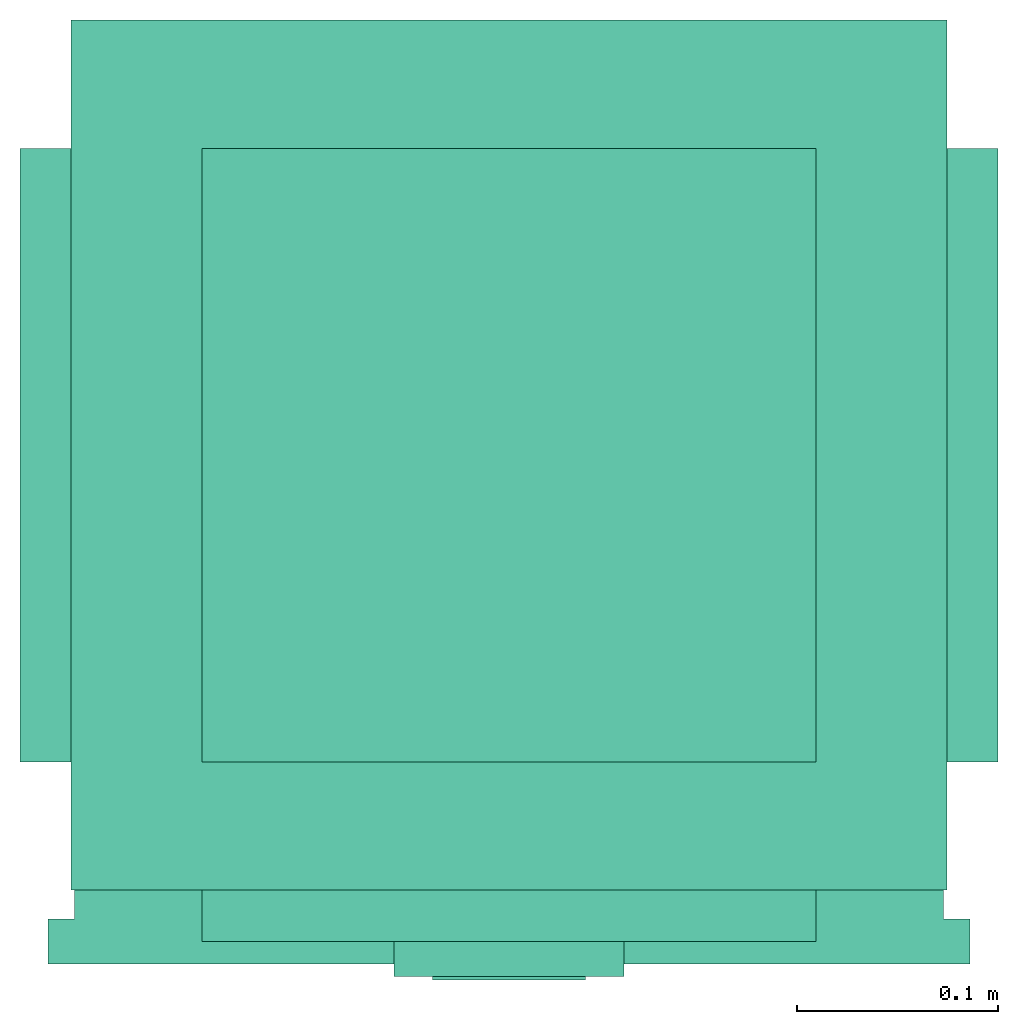
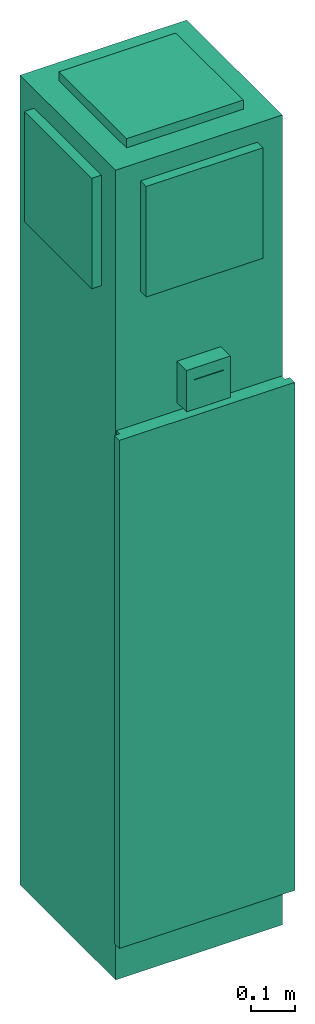
# One storey: 1 energy conversion device.
"""IFC2X3 building model written with IfcOpenShell, lengths in metres."""

from ifc_helpers import new_model, entity, si_unit, converted_unit, origin, origin_with_axes, place, context, subcontext, project, spatial, faceted_brep, type_object, element, save


model = new_model("IFC2X3")

# Units and contexts
model_context = context("Model", 3, precision=1e-05, world=origin())
body_context = subcontext(model_context, "Body", "Model", "MODEL_VIEW")
ifc_project = project(units=[si_unit("LENGTHUNIT", "METRE"), si_unit("AREAUNIT", "SQUARE_METRE"), si_unit("VOLUMEUNIT", "CUBIC_METRE"), converted_unit("PLANEANGLEUNIT", "DEGREE", entity("IfcPlaneAngleMeasure", 0.0174532925199433), si_unit("PLANEANGLEUNIT", "RADIAN"), dimensions=[0, 0, 0, 0, 0, 0, 0]), si_unit("SOLIDANGLEUNIT", "STERADIAN"), si_unit("MASSUNIT", "GRAM"), si_unit("TIMEUNIT", "SECOND"), si_unit("THERMODYNAMICTEMPERATUREUNIT", "DEGREE_CELSIUS"), si_unit("LUMINOUSINTENSITYUNIT", "LUMEN")], contexts=[model_context])

# Site, building, storey
site_placement = place(None, origin_with_axes())
site = spatial("IfcSite", under=ifc_project, at=site_placement, CompositionType="ELEMENT")
building_placement = place(site_placement, origin_with_axes())
building = spatial("IfcBuilding", under=site, at=building_placement, CompositionType="ELEMENT")
storey_placement = place(building_placement, origin_with_axes())
storey = spatial("IfcBuildingStorey", under=building, at=storey_placement, CompositionType="ELEMENT", Elevation=0.0)

# Energy conversion device
heat_exchanger_type = type_object("IfcHeatExchangerType", Name="Hi Rise Fan Coil Unit (FCU)", PredefinedType="NOTDEFINED")
energy_conversion_device_placement = place(storey_placement, origin_with_axes())
element("IfcEnergyConversionDevice", 1, at=energy_conversion_device_placement, inside=storey, type_object=heat_exchanger_type, Name="Rise Fan Coil Unit (FCU)", context=body_context, shape_type="Brep", body=[
    faceted_brep([(-0.129934510803223, 0.1524, 2.18225827026367), (-0.129934510803223, 0.1524, 1.87745827026367), (-0.155334510803223, 0.1524, 1.87745827026367), (-0.155334510803223, 0.1524, 2.18225827026367), (-0.129934510803223, -0.1524, 1.87745827026367), (-0.155334510803223, -0.1524, 1.87745827026367), (-0.129934510803223, -0.1524, 2.18225827026367), (-0.155334510803223, -0.1524, 2.18225827026367)], [[[0, 1, 2]], [[2, 3, 0]], [[1, 4, 5]], [[5, 2, 1]], [[4, 6, 7]], [[7, 5, 4]], [[6, 0, 3]], [[3, 7, 6]], [[6, 1, 0]], [[1, 6, 4]], [[7, 3, 2]], [[2, 5, 7]]]),
    faceted_brep([(-0.129934510803223, -7.21911419532262e-16, 2.23457697601318), (-0.129934510803223, 0.216141288566589, 2.23457697601318), (-0.129934510803223, 0.216141288566589, 0.000123923291545361), (-0.129934510803223, -7.21911419532262e-16, 0.000123923291545361), (0.305040489196778, 0.216141288566589, 2.23457697601318), (0.305040489196778, 0.216141288566589, 0.000123923291545361), (0.305040489196778, -0.216141288566589, 2.23457697601318), (0.305040489196778, -0.216141288566589, 0.000123923291545361), (-0.129934510803223, -0.216141288566589, 2.23457697601318), (-0.129934510803223, -0.216141288566589, 0.000123923291545361)], [[[0, 1, 2]], [[2, 3, 0]], [[1, 4, 5]], [[5, 2, 1]], [[4, 6, 7]], [[7, 5, 4]], [[6, 8, 9]], [[9, 7, 6]], [[8, 0, 3]], [[3, 9, 8]], [[0, 4, 1]], [[8, 6, 0]], [[4, 0, 6]], [[3, 2, 5]], [[9, 3, 7]], [[5, 7, 3]]]),
    faceted_brep([(-0.0648470108032227, -0.216141288566589, 2.18225827026367), (-0.0648470108032227, -0.216141288566589, 1.87745827026367), (-0.0648470108032227, -0.241541288566589, 1.87745827026367), (-0.0648470108032227, -0.241541288566589, 2.18225827026367), (0.239952989196777, -0.216141288566589, 1.87745827026367), (0.239952989196777, -0.241541288566589, 1.87745827026367), (0.239952989196777, -0.216141288566589, 2.18225827026367), (0.239952989196777, -0.241541288566589, 2.18225827026367)], [[[0, 1, 2]], [[2, 3, 0]], [[1, 4, 5]], [[5, 2, 1]], [[4, 6, 7]], [[7, 5, 4]], [[6, 0, 3]], [[3, 7, 6]], [[6, 1, 0]], [[1, 6, 4]], [[7, 3, 2]], [[2, 5, 7]]]),
    faceted_brep([(-0.0648470108032227, 0.1524, 2.23457716979981), (-0.0648470108032227, -0.1524, 2.23457716979981), (-0.0648470108032227, -0.1524, 2.25997716979981), (-0.0648470108032227, 0.1524, 2.25997716979981), (0.239952989196777, -0.1524, 2.23457716979981), (0.239952989196777, -0.1524, 2.25997716979981), (0.239952989196777, 0.1524, 2.23457716979981), (0.239952989196777, 0.1524, 2.25997716979981)], [[[0, 1, 2]], [[2, 3, 0]], [[1, 4, 5]], [[5, 2, 1]], [[4, 6, 7]], [[7, 5, 4]], [[6, 0, 3]], [[3, 7, 6]], [[6, 1, 0]], [[1, 6, 4]], [[7, 3, 2]], [[2, 5, 7]]]),
    faceted_brep([(-0.141427995300293, -0.24162512550354, 0.113199582672119), (-0.141427995300293, -0.25273762550354, 0.113199582672119), (-0.141427995300293, -0.25273762550354, 1.51509763641357), (-0.141427995300293, -0.24162512550354, 1.51509763641357), (0.316533997917174, -0.25273762550354, 0.113199582672119), (0.316533997917174, -0.25273762550354, 1.51509763641357), (0.316533997917174, -0.23051262550354, 0.113199582672119), (0.316533997917174, -0.23051262550354, 1.51509763641357), (0.303389499855042, -0.23051262550354, 0.113199582672119), (0.303389499855042, -0.23051262550354, 1.51509763641357), (0.303389499855042, -0.216141288566589, 0.113199582672119), (0.303389499855042, -0.216141288566589, 1.51509763641357), (-0.128283497238159, -0.216141288566589, 0.113199582672119), (-0.128283497238159, -0.216141288566589, 1.51509763641357), (-0.128283497238159, -0.23051262550354, 0.113199582672119), (-0.128283497238159, -0.23051262550354, 1.51509763641357), (-0.141427995300293, -0.23051262550354, 0.113199582672119), (-0.141427995300293, -0.23051262550354, 1.51509763641357)], [[[0, 1, 2]], [[2, 3, 0]], [[1, 4, 5]], [[5, 2, 1]], [[4, 6, 7]], [[7, 5, 4]], [[6, 8, 9]], [[9, 7, 6]], [[8, 10, 11]], [[11, 9, 8]], [[10, 12, 13]], [[13, 11, 10]], [[12, 14, 15]], [[15, 13, 12]], [[14, 16, 17]], [[17, 15, 14]], [[16, 0, 3]], [[3, 17, 16]], [[14, 8, 1]], [[4, 1, 8]], [[14, 1, 0]], [[0, 16, 14]], [[8, 14, 12]], [[10, 8, 12]], [[6, 4, 8]], [[15, 2, 9]], [[5, 9, 2]], [[15, 3, 2]], [[3, 15, 17]], [[9, 13, 15]], [[11, 13, 9]], [[7, 9, 5]]]),
    faceted_brep([(0.0494529891967773, -0.248036991882324, 1.61977516174316), (0.0494529891967773, -0.248036991882324, 1.56897516174316), (0.0494529891967773, -0.260736991882324, 1.56897516174316), (0.0494529891967773, -0.260736991882324, 1.61977516174316), (0.125652989196777, -0.248036991882324, 1.56897516174316), (0.125652989196777, -0.260736991882324, 1.56897516174316), (0.125652989196777, -0.248036991882324, 1.61977516174316), (0.125652989196777, -0.260736991882324, 1.61977516174316)], [[[0, 1, 2]], [[2, 3, 0]], [[1, 4, 5]], [[5, 2, 1]], [[4, 6, 7]], [[7, 5, 4]], [[6, 0, 3]], [[3, 7, 6]], [[1, 0, 6]], [[6, 4, 1]], [[2, 7, 3]], [[7, 2, 5]]]),
    faceted_brep([(0.305040489196778, 0.1524, 2.18225827026367), (0.305040489196778, -0.1524, 2.18225827026367), (0.330440489196778, -0.1524, 2.18225827026367), (0.330440489196778, 0.1524, 2.18225827026367), (0.305040489196778, -0.1524, 1.87745827026367), (0.330440489196778, -0.1524, 1.87745827026367), (0.305040489196778, 0.1524, 1.87745827026367), (0.330440489196778, 0.1524, 1.87745827026367)], [[[0, 1, 2]], [[2, 3, 0]], [[1, 4, 5]], [[5, 2, 1]], [[4, 6, 7]], [[7, 5, 4]], [[6, 0, 3]], [[3, 7, 6]], [[6, 4, 1]], [[1, 0, 6]], [[7, 2, 5]], [[2, 7, 3]]]),
    faceted_brep([(0.0304029891967773, -0.258889502906799, 1.53722516174316), (0.0304029891967773, -0.258889502906799, 1.65152516174316), (0.0304029891967773, -0.216141288566589, 1.65152516174316), (0.0304029891967773, -0.216141288566589, 1.53722516174316), (0.144702989196777, -0.258889502906799, 1.65152516174316), (0.144702989196777, -0.216141288566589, 1.65152516174316), (0.144702989196777, -0.258889502906799, 1.53722516174316), (0.144702989196777, -0.216141288566589, 1.53722516174316)], [[[0, 1, 2]], [[2, 3, 0]], [[1, 4, 5]], [[5, 2, 1]], [[4, 6, 7]], [[7, 5, 4]], [[6, 0, 3]], [[3, 7, 6]], [[1, 0, 6]], [[6, 4, 1]], [[2, 7, 3]], [[7, 2, 5]]]),
])

save(model, "model.ifc")
